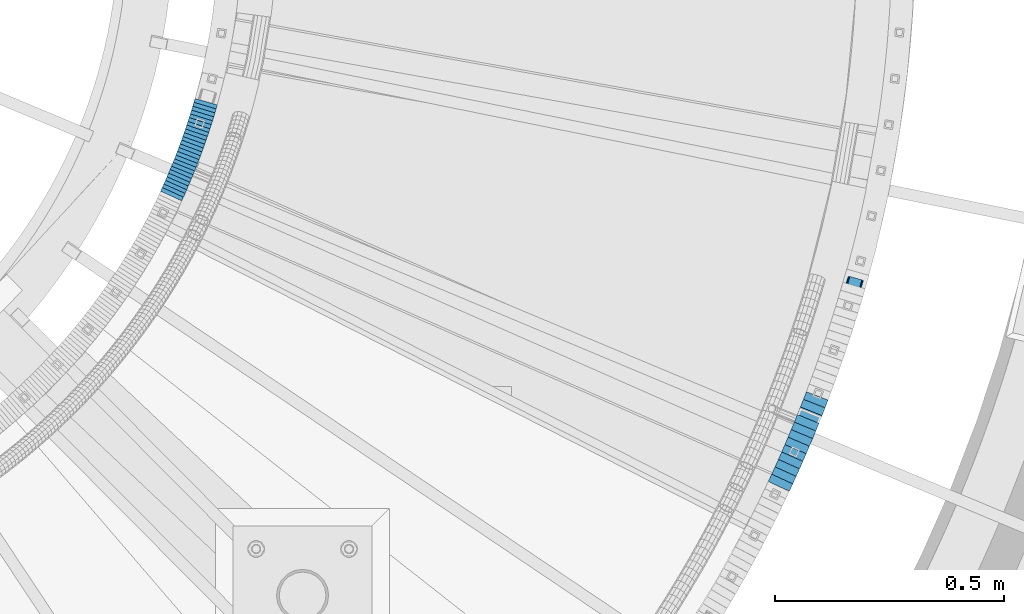
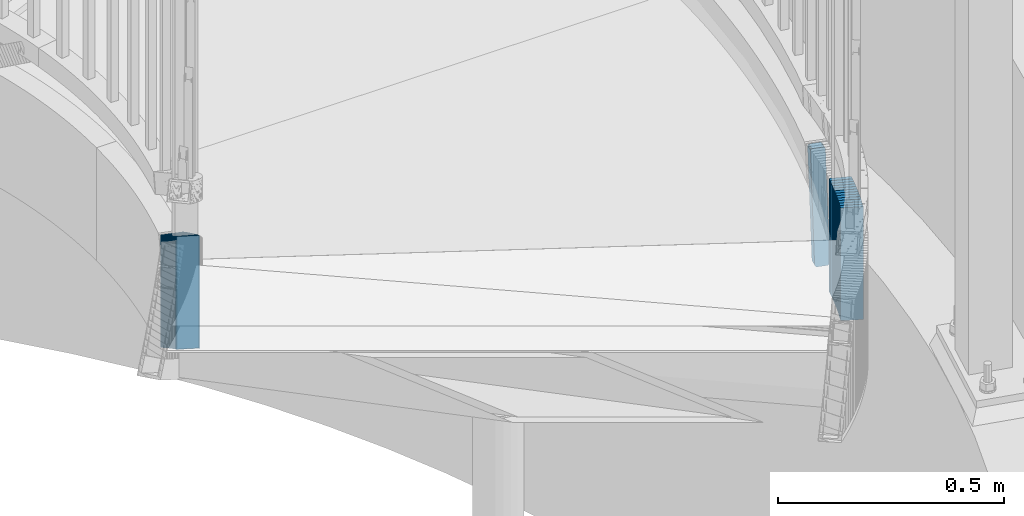
# One storey, part 908 of 975: 38 plates.
"""IFC2X3 building model written with IfcOpenShell, lengths in millimetres."""

import ifcopenshell
import ifcopenshell.guid

model = None  # the IFC model being written
_history = None  # IfcOwnerHistory: only IFC2X3 demands one
_inside = {}  # id of a spatial element -> (the spatial element, [elements in it])
_under = {}  # id of a project, library or spatial element -> (it, [spatial elements below it])
_declared = {}  # id of a project -> (the project, [libraries it declares])
_typed = {}  # id of a type object -> (the type object, [elements of that type])
_made_of = {}  # id of a material, layer set ... -> (it, [elements and type objects made of it])


def new_model(schema):
    """Start an empty IFC model of exactly this schema.

    Asked for "IFC4X3", IfcOpenShell would pick the latest addendum, in which some entities
    have other attributes; the version numbers below select the first issue.
    IFC2X3 requires an IfcOwnerHistory on every rooted entity: one is made here for all.
    """
    global model, _history
    if schema == "IFC4X3":
        model = ifcopenshell.file(schema_version=(4, 3, 0, 0))
    else:
        model = ifcopenshell.file(schema=schema)
    _inside.clear()
    _under.clear()
    _declared.clear()
    _typed.clear()
    _made_of.clear()
    _history = None
    if model.schema == "IFC2X3":
        org = make("IfcOrganization", Name="unknown")
        user = make(
            "IfcPersonAndOrganization",
            ThePerson=make("IfcPerson", FamilyName="unknown"),
            TheOrganization=org,
        )
        app = make(
            "IfcApplication",
            ApplicationDeveloper=org,
            Version="unknown",
            ApplicationFullName="unknown",
            ApplicationIdentifier="unknown",
        )
        _history = make(
            "IfcOwnerHistory",
            OwningUser=user,
            OwningApplication=app,
            ChangeAction="ADDED",
            CreationDate=0,
        )
    return model


def make(cls, **values):
    """One entity of the class cls with the attributes given. An attribute that is None is left unset."""
    return model.create_entity(
        cls, **{name: value for name, value in values.items() if value is not None}
    )


def rooted(cls, **values):
    """An entity with a GlobalId (a new one), such as an element, a storey or a relation."""
    return make(cls, GlobalId=ifcopenshell.guid.new(), OwnerHistory=_history, **values)


def si_unit(unit_type, name, prefix=None):
    """IfcSIUnit, for example si_unit("LENGTHUNIT", "METRE", prefix="MILLI")."""
    return make("IfcSIUnit", UnitType=unit_type, Prefix=prefix, Name=name)


def assignment(units):
    """IfcUnitAssignment: the units of a project."""
    return None if units is None else make("IfcUnitAssignment", Units=units)


def point(xyz):
    """IfcCartesianPoint."""
    return None if xyz is None else make("IfcCartesianPoint", Coordinates=xyz)


def direction(xyz):
    """IfcDirection."""
    return None if xyz is None else make("IfcDirection", DirectionRatios=xyz)


def frame(location, z_axis=None, x_axis=None):
    """IfcAxis2Placement3D, a coordinate frame: its origin and axes. An axis left out is left unset."""
    return make(
        "IfcAxis2Placement3D",
        Location=point(location),
        Axis=direction(z_axis),
        RefDirection=direction(x_axis),
    )


def origin_with_axes():
    """The frame at (0, 0, 0) with the z axis (0, 0, 1) and the x axis (1, 0, 0) written out."""
    return frame((0.0, 0.0, 0.0), z_axis=(0.0, 0.0, 1.0), x_axis=(1.0, 0.0, 0.0))


def place(relative_to, where):
    """IfcLocalPlacement: puts the frame where relative to a parent placement (None: the world)."""
    return make(
        "IfcLocalPlacement", PlacementRelTo=relative_to, RelativePlacement=where
    )


def context(
    kind, dimensions, precision=None, world=None, true_north=None, identifier=None
):
    """IfcGeometricRepresentationContext, for example the 3D "Model" context."""
    return make(
        "IfcGeometricRepresentationContext",
        ContextIdentifier=identifier,
        ContextType=kind,
        CoordinateSpaceDimension=dimensions,
        Precision=precision,
        WorldCoordinateSystem=world,
        TrueNorth=true_north,
    )


def subcontext(parent, identifier, kind, view, scale=None):
    """IfcGeometricRepresentationSubContext, for example "Body" below "Model"."""
    return make(
        "IfcGeometricRepresentationSubContext",
        ContextIdentifier=identifier,
        ContextType=kind,
        ParentContext=parent,
        TargetScale=scale,
        TargetView=view,
    )


def project(units=None, contexts=None):
    """IfcProject with its units and contexts."""
    return rooted(
        "IfcProject",
        Name="project",
        RepresentationContexts=contexts,
        UnitsInContext=assignment(units),
    )


def spatial(cls, under=None, at=None, **own):
    """A site, building, storey or space (cls), placed at a placement, below another one or the project."""
    s = rooted(cls, ObjectPlacement=at, **own)
    if under is not None:
        _under.setdefault(under.id(), (under, []))[1].append(s)
    return s


def faces_of(points, faces, orient=None, outer=None):
    """IfcFace entities. A face is a list of loops; a loop is a list of indices into points, from 0.

    orient and outer hold one flag for each loop. By default every Orientation is true, the
    first loop of a face is its IfcFaceOuterBound and the others are IfcFaceBound.
    """
    made = []
    for i, loops in enumerate(faces):
        bounds = []
        for j, loop in enumerate(loops):
            is_outer = j == 0 if outer is None else outer[i][j]
            bounds.append(
                make(
                    "IfcFaceOuterBound" if is_outer else "IfcFaceBound",
                    Bound=make("IfcPolyLoop", Polygon=[points[k] for k in loop]),
                    Orientation=True if orient is None else orient[i][j],
                )
            )
        made.append(make("IfcFace", Bounds=bounds))
    return made


def faceted_brep(points, faces, orient=None, outer=None, voids=None):
    """IfcFacetedBrep: a solid bounded by flat faces; with voids (closed shells), ...WithVoids."""
    shared = [point(p) for p in points]
    hull = make("IfcClosedShell", CfsFaces=faces_of(shared, faces, orient, outer))
    if voids is None:
        return make("IfcFacetedBrep", Outer=hull)
    return make(
        "IfcFacetedBrepWithVoids",
        Outer=hull,
        Voids=[
            make(cls, CfsFaces=faces_of(shared, fs, o, b)) for cls, fs, o, b in voids
        ],
    )


def shape(context_of_items, identifier, shape_type, items):
    """IfcShapeRepresentation: the items that make up one representation, for example the "Body"."""
    return make(
        "IfcShapeRepresentation",
        ContextOfItems=context_of_items,
        RepresentationIdentifier=identifier,
        RepresentationType=shape_type,
        Items=items,
    )


def material(Name=None, Category=None):
    """IfcMaterial."""
    return make("IfcMaterial", Name=Name, Category=Category)


def made_of(thing, what):
    """Note that an element or type object is made of a material, layer set ...; save() writes the relation."""
    if what is not None:
        _made_of.setdefault(what.id(), (what, []))[1].append(thing)
    return thing


def type_object(cls, material=None, **own):
    """A type object (cls), such as IfcWallType, which elements share."""
    return made_of(rooted(cls, **own), material)


def element(
    cls,
    number,
    at=None,
    inside=None,
    cuts=None,
    type_object=None,
    material=None,
    context=None,
    identifier="Body",
    shape_type=None,
    held_by="IfcProductDefinitionShape",
    body=None,
    shapes=None,
    **own,
):
    """One element of the class cls, such as IfcWall. Its Tag is "e" and its number.

    at: its placement. inside: the storey or other place that contains it. cuts: it is an
    opening in that element (IfcRelVoidsElement). A single representation is given by context,
    identifier, shape_type and body (its items); several are given by shapes. held_by: the class
    of the entity that holds the representations. save() writes the other relations.
    """
    e = rooted(cls, Tag="e%d" % number, ObjectPlacement=at, **own)
    if body is not None:
        shapes = [shape(context, identifier, shape_type, body)]
    if shapes is not None:
        e.Representation = make(held_by, Representations=shapes)
    if inside is not None:
        _inside.setdefault(inside.id(), (inside, []))[1].append(e)
    if cuts is not None:
        rooted(
            "IfcRelVoidsElement", RelatingBuildingElement=cuts, RelatedOpeningElement=e
        )
    if type_object is not None:
        _typed.setdefault(type_object.id(), (type_object, []))[1].append(e)
    return made_of(e, material)


def aggregate(whole, parts):
    """IfcRelAggregates: a whole, such as a stair, and the parts it consists of."""
    return rooted("IfcRelAggregates", RelatingObject=whole, RelatedObjects=parts)


def save(model, path):
    """Write the relations noted so far, then the file.

    IfcRelAggregates (storeys below a building ...), IfcRelContainedInSpatialStructure (elements
    in a storey), IfcRelDefinesByType, IfcRelAssociatesMaterial and IfcRelDeclares: one each for
    every whole, place, type object, material and project.
    """
    for whole, parts in _under.values():
        aggregate(whole, parts)
    for where, things in _inside.values():
        rooted(
            "IfcRelContainedInSpatialStructure",
            RelatedElements=things,
            RelatingStructure=where,
        )
    for kind, things in _typed.values():
        rooted("IfcRelDefinesByType", RelatedObjects=things, RelatingType=kind)
    for what, things in _made_of.values():
        rooted("IfcRelAssociatesMaterial", RelatedObjects=things, RelatingMaterial=what)
    for by, libraries in _declared.values():
        rooted("IfcRelDeclares", RelatingContext=by, RelatedDefinitions=libraries)
    model.write(path)


model = new_model("IFC2X3")

# Units and contexts
model_context = context("Model", 3, precision=1e-05, world=origin_with_axes())
body_context = subcontext(model_context, "Body", "Model", "MODEL_VIEW")
ifc_project = project(units=[si_unit("LENGTHUNIT", "METRE", prefix="MILLI"), si_unit("AREAUNIT", "SQUARE_METRE"), si_unit("VOLUMEUNIT", "CUBIC_METRE"), si_unit("MASSUNIT", "GRAM", prefix="KILO"), si_unit("TIMEUNIT", "SECOND"), si_unit("PLANEANGLEUNIT", "RADIAN"), si_unit("SOLIDANGLEUNIT", "STERADIAN"), si_unit("THERMODYNAMICTEMPERATUREUNIT", "DEGREE_CELSIUS"), si_unit("LUMINOUSINTENSITYUNIT", "LUMEN")], contexts=[model_context])

# Site, building, storey
site_placement = place(None, origin_with_axes())
site = spatial("IfcSite", under=ifc_project, at=site_placement, CompositionType="ELEMENT")
building_placement = place(site_placement, origin_with_axes())
building = spatial("IfcBuilding", under=site, at=building_placement, Name="Undefined", CompositionType="ELEMENT")
storey_placement = place(building_placement, origin_with_axes())
storey = spatial("IfcBuildingStorey", under=building, at=storey_placement, Name="Undefined", CompositionType="ELEMENT", Elevation=0.0)

# Plates
ifc_material = material(Name="STEEL/A36")
plate_type_1 = type_object("IfcPlateType", PredefinedType="NOTDEFINED")
plate_1_placement = place(storey_placement, frame((37513.5290251012, 2619.93228842539, 2176.46249923706), z_axis=(-0.042643257613985, -0.150480033117174, -0.987692924047308), x_axis=(-0.962114570717468, 0.272645470919916, 0.0)))
element("IfcPlate", 1, at=plate_1_placement, inside=storey, type_object=plate_type_1, material=ifc_material, Name="PLATE", context=body_context, shape_type="Brep", body=[
    faceted_brep([(0.0283717790953233, -12.6999999999807, 6.37824576082949), (1.27309277207678, -12.6999999999443, 286.203361918336), (1.27309277216409, 12.7000000000317, 286.203361918335), (0.0283717791753588, 12.6999999999916, 6.37824576082858), (1.76453448672692, -12.6999999999425, 288.624714152793), (1.76453448681423, 12.7000000000298, 288.624714152792), (3.14289941047173, -12.6999999999443, 290.675219392782), (3.14289941055904, 12.7000000000298, 290.67521939278), (5.19951556106389, -12.6999999999462, 292.044449691656), (5.1995155611512, 12.700000000028, 292.044449691655), (7.6230298552764, -12.699999999948, 292.525115966766), (7.62302985536371, 12.7000000000262, 292.525115966765), (29.8509887055552, -12.6999999999625, 292.525115966769), (29.8509887056425, 12.7000000000098, 292.525115966768), (32.2875833799626, -12.6999999999662, 292.039031578372), (32.2875833800499, 12.7000000000098, 292.039031578371), (34.3511416292095, -12.699999999968, 290.655196692296), (34.3511416292968, 12.700000000008, 290.655196692295), (35.7257379526418, -12.699999999968, 288.585472897311), (35.7257379527291, 12.7000000000044, 288.58547289731), (36.2009251618729, -12.699999999968, 286.146729623383), (36.2009251619602, 12.7000000000044, 286.146729623382), (34.9500089401045, -12.7000000000098, 6.32161346586145), (34.9500089401918, 12.6999999999643, 6.32161346586145), (34.4585271774267, -12.7000000000098, 3.90030453747113), (34.458527177514, 12.6999999999643, 3.90030453747022), (33.0801531139732, -12.700000000008, 1.84984698097833), (33.0801531140532, 12.6999999999662, 1.84984698097833), (31.0235542923692, -12.7000000000062, 0.480652861512681), (31.0235542924565, 12.6999999999662, 0.480652861511771), (28.6000724837941, -12.7000000000062, -1.63709046319127e-11), (28.6000724838814, 12.699999999968, -1.72803993336856e-11), (6.37830886230222, -12.699999999988, -3.63797880709171e-12), (6.37830886238953, 12.6999999999844, -4.54747350886464e-12), (3.94174664354068, -12.6999999999862, 0.486070902416941), (3.94174664362799, 12.699999999988, 0.486070902416031), (1.87820553164784, -12.6999999999862, 1.86986945984154), (1.87820553173515, 12.699999999988, 1.86986945984063), (0.503599638563173, -12.6999999999844, 3.93954552307878), (0.503599638650485, 12.6999999999916, 3.93954552307878)], [[[0, 1, 2, 3]], [[1, 4, 5, 2]], [[4, 6, 7, 5]], [[6, 8, 9, 7]], [[8, 10, 11, 9]], [[10, 12, 13, 11]], [[12, 14, 15, 13]], [[14, 16, 17, 15]], [[16, 18, 19, 17]], [[18, 20, 21, 19]], [[20, 22, 23, 21]], [[22, 24, 25, 23]], [[24, 26, 27, 25]], [[26, 28, 29, 27]], [[28, 30, 31, 29]], [[30, 32, 33, 31]], [[32, 34, 35, 33]], [[34, 36, 37, 35]], [[36, 38, 39, 37]], [[38, 0, 3, 39]], [[5, 7, 9, 11, 13, 15, 17, 19, 21, 23, 25, 27, 29, 31, 33, 35, 37, 39, 3, 2]], [[38, 36, 34, 32, 30, 28, 26, 24, 22, 20, 18, 16, 14, 12, 10, 8, 6, 4, 1, 0]]]),
])
plate_type_2 = type_object("IfcPlateType", PredefinedType="NOTDEFINED")
for number, where, z_axis, x_axis, name in (
    (2, (37338.9703664102, 2197.3945374098, 2024.98750006771), (-0.417626109916978, -0.908618969819369, 0.0), (0.0, 0.0, 1.0), "WALL"),
    (3, (37346.3703664099, 2213.49453740977, 2019.28750006771), (-0.417626109916978, -0.908618969819369, 0.0), (0.0, 0.0, 1.0), "WALL"),
):
    element("IfcPlate", number, at=place(storey_placement, frame(where, z_axis=z_axis, x_axis=x_axis)), inside=storey, type_object=plate_type_2, material=ifc_material, Name=name, context=body_context, shape_type="Brep", body=[
        faceted_brep([(0.0, -25.3999999999724, -1.81898940354586e-11), (5.69999980926514, -25.3999999999869, 17.7191982269287), (5.69999980926514, 25.4000000000815, 17.7191982269651), (0.0, 25.3999999999869, 1.45519152283669e-11), (310.5, -25.3999999999869, 17.7191982269287), (310.5, 25.4000000000815, 17.7191982269651), (304.799987792969, -25.3999999999724, -1.81898940354586e-11), (304.799987792969, 25.3999999999869, 1.45519152283669e-11)], [[[0, 1, 2, 3]], [[1, 4, 5, 2]], [[4, 6, 7, 5]], [[6, 0, 3, 7]], [[5, 7, 3, 2]], [[6, 4, 1, 0]]]),
    ])
plate_2_placement = place(storey_placement, frame((37353.7488983846, 2229.86709167442, 2013.68750006771), z_axis=(-0.410832634928258, -0.911710779840792, 0.0), x_axis=(0.0, 0.0, 1.0)))
element("IfcPlate", 4, at=plate_2_placement, inside=storey, type_object=plate_type_2, material=ifc_material, Name="WALL", context=body_context, shape_type="Brep", body=[
    faceted_brep([(0.0, -25.3999999999724, -1.81898940354586e-11), (5.59999990463257, -25.3999999998778, 17.76879310613), (5.59999990463257, 25.3999999999724, 17.7687931060609), (0.0, 25.3999999999869, 1.45519152283669e-11), (310.399993896485, -25.3999999998778, 17.76879310613), (310.399993896485, 25.3999999999724, 17.7687931060609), (304.799987792969, -25.3999999999724, -1.81898940354586e-11), (304.799987792969, 25.3999999999869, 1.45519152283669e-11)], [[[0, 1, 2, 3]], [[1, 4, 5, 2]], [[4, 6, 7, 5]], [[6, 0, 3, 7]], [[5, 7, 3, 2]], [[6, 4, 1, 0]]]),
])
plate_3_placement = place(storey_placement, frame((37361.002257914, 2246.18632356852, 2007.98750006771), z_axis=(-0.40613846586788, -0.913811548702732, 0.0), x_axis=(0.0, 0.0, 1.0)))
element("IfcPlate", 5, at=plate_3_placement, inside=storey, type_object=plate_type_2, material=ifc_material, Name="WALL", context=body_context, shape_type="Brep", body=[
    faceted_brep([(0.0, -25.3999999999724, -1.81898940354586e-11), (5.69999980926514, -25.3999999998996, 17.7279434204574), (5.69999980926514, 25.3999999999869, 17.7279434203992), (0.0, 25.3999999999869, 1.45519152283669e-11), (310.5, -25.3999999998996, 17.7279434204574), (310.5, 25.3999999999869, 17.7279434203992), (304.799987792969, -25.3999999999724, -1.81898940354586e-11), (304.799987792969, 25.3999999999869, 1.45519152283669e-11)], [[[0, 1, 2, 3]], [[1, 4, 5, 2]], [[4, 6, 7, 5]], [[6, 0, 3, 7]], [[5, 7, 3, 2]], [[6, 4, 1, 0]]]),
])
for number, where, z_axis, x_axis, name in (
    (6, (37368.130315909, 2262.7794124118, 2002.28750006771), (-0.394599535030015, -0.918853202069893, 0.0), (0.0, 0.0, 1.0), "WALL"),
    (7, (37375.1303159085, 2279.07941241171, 1996.58750006771), (-0.394599535030015, -0.918853202069893, 0.0), (0.0, 0.0, 1.0), "WALL"),
):
    element("IfcPlate", number, at=place(storey_placement, frame(where, z_axis=z_axis, x_axis=x_axis)), inside=storey, type_object=plate_type_2, material=ifc_material, Name=name, context=body_context, shape_type="Brep", body=[
        faceted_brep([(0.0, -25.3999999999724, -1.81898940354586e-11), (5.69999980926514, -25.3999999999833, 17.7428855895923), (5.69999980926514, 25.4000000000051, 17.7428855895996), (0.0, 25.3999999999869, 1.45519152283669e-11), (310.5, -25.3999999999833, 17.7428855895923), (310.5, 25.4000000000051, 17.7428855895996), (304.799987792969, -25.3999999999724, -1.81898940354586e-11), (304.799987792969, 25.3999999999869, 1.45519152283669e-11)], [[[0, 1, 2, 3]], [[1, 4, 5, 2]], [[4, 6, 7, 5]], [[6, 0, 3, 7]], [[5, 7, 3, 2]], [[6, 4, 1, 0]]]),
    ])
plate_4_placement = place(storey_placement, frame((37382.1036694327, 2295.65197526172, 1990.88750006771), z_axis=(-0.387805722036741, -0.92174113608733, 0.0), x_axis=(0.0, 0.0, 1.0)))
element("IfcPlate", 8, at=plate_4_placement, inside=storey, type_object=plate_type_2, material=ifc_material, Name="WALL", context=body_context, shape_type="Brep", body=[
    faceted_brep([(0.0, -25.3999999999724, -1.81898940354586e-11), (5.69999980926514, -25.4000000000251, 17.7924137116061), (5.69999980926514, 25.4000000000051, 17.7924137115479), (0.0, 25.3999999999869, 1.45519152283669e-11), (310.5, -25.4000000000251, 17.7924137116061), (310.5, 25.4000000000051, 17.7924137115479), (304.799987792969, -25.3999999999724, -1.81898940354586e-11), (304.799987792969, 25.3999999999869, 1.45519152283669e-11)], [[[0, 1, 2, 3]], [[1, 4, 5, 2]], [[4, 6, 7, 5]], [[6, 0, 3, 7]], [[5, 7, 3, 2]], [[6, 4, 1, 0]]]),
])
plate_5_placement = place(storey_placement, frame((37388.9544942598, 2312.17365902218, 1985.18750006771), z_axis=(-0.383015022804495, -0.923742113528485, 0.0), x_axis=(0.0, 0.0, 1.0)))
element("IfcPlate", 9, at=plate_5_placement, inside=storey, type_object=plate_type_2, material=ifc_material, Name="WALL", context=body_context, shape_type="Brep", body=[
    faceted_brep([(0.0, -25.3999999999724, -1.81898940354586e-11), (5.69999980926514, -25.3999999999724, 17.7538719177392), (5.69999980926514, 25.3999999999069, 17.7538719176846), (0.0, 25.3999999999869, 1.45519152283669e-11), (310.5, -25.3999999999724, 17.7538719177392), (310.5, 25.3999999999069, 17.7538719176846), (304.799987792969, -25.3999999999724, -1.81898940354586e-11), (304.799987792969, 25.3999999999869, 1.45519152283669e-11)], [[[0, 1, 2, 3]], [[1, 4, 5, 2]], [[4, 6, 7, 5]], [[6, 0, 3, 7]], [[5, 7, 3, 2]], [[6, 4, 1, 0]]]),
])
plate_6_placement = place(storey_placement, frame((37395.7252495328, 2328.84608948038, 1979.38750006771), z_axis=(-0.376226422085929, -0.926527754211616, 0.0), x_axis=(0.0, 0.0, 1.0)))
element("IfcPlate", 10, at=plate_6_placement, inside=storey, type_object=plate_type_2, material=ifc_material, Name="WALL", context=body_context, shape_type="Brep", body=[
    faceted_brep([(0.0, -25.3999999999724, -1.81898940354586e-11), (5.80000019073486, -25.3999999999542, 17.8084259032221), (5.80000019073486, 25.3999999999833, 17.8084259033567), (0.0, 25.3999999999869, 1.45519152283669e-11), (310.600006103516, -25.3999999999542, 17.8084259032221), (310.600006103516, 25.3999999999833, 17.8084259033567), (304.799987792969, -25.3999999999724, -1.81898940354586e-11), (304.799987792969, 25.3999999999869, 1.45519152283669e-11)], [[[0, 1, 2, 3]], [[1, 4, 5, 2]], [[4, 6, 7, 5]], [[6, 0, 3, 7]], [[5, 7, 3, 2]], [[6, 4, 1, 0]]]),
])
for number, where, z_axis, x_axis, name in (
    (11, (37402.3943134138, 2345.61796745032, 1973.68750006771), (-0.369459572873638, -0.929246804682173, 0.0), (0.0, 0.0, 1.0), "WALL"),
    (12, (37408.9943134128, 2362.2179674503, 1967.98750006771), (-0.369459572873638, -0.929246804682173, 0.0), (0.0, 0.0, 1.0), "WALL"),
):
    element("IfcPlate", number, at=place(storey_placement, frame(where, z_axis=z_axis, x_axis=x_axis)), inside=storey, type_object=plate_type_2, material=ifc_material, Name=name, context=body_context, shape_type="Brep", body=[
        faceted_brep([(0.0, -25.3999999999724, -1.81898940354586e-11), (5.69999980926514, -25.4000000000378, 17.8639297485788), (5.69999980926514, 25.3999999999833, 17.8639297485533), (0.0, 25.3999999999869, 1.45519152283669e-11), (310.5, -25.4000000000378, 17.8639297485788), (310.5, 25.3999999999833, 17.8639297485533), (304.799987792969, -25.3999999999724, -1.81898940354586e-11), (304.799987792969, 25.3999999999869, 1.45519152283669e-11)], [[[0, 1, 2, 3]], [[1, 4, 5, 2]], [[4, 6, 7, 5]], [[6, 0, 3, 7]], [[5, 7, 3, 2]], [[6, 4, 1, 0]]]),
    ])
plate_7_placement = place(storey_placement, frame((37415.5093869884, 2379.21272974412, 1962.28750006771), z_axis=(-0.357854758158108, -0.933777260412569, 0.0), x_axis=(0.0, 0.0, 1.0)))
element("IfcPlate", 13, at=plate_7_placement, inside=storey, type_object=plate_type_2, material=ifc_material, Name="WALL", context=body_context, shape_type="Brep", body=[
    faceted_brep([(0.0, -25.3999999999724, -1.81898940354586e-11), (5.69999980926514, -25.3999999999687, 17.8807163238307), (5.69999980926514, 25.400000000016, 17.880716323838), (0.0, 25.3999999999869, 1.45519152283669e-11), (310.5, -25.3999999999687, 17.8807163238307), (310.5, 25.400000000016, 17.880716323838), (304.799987792969, -25.3999999999724, -1.81898940354586e-11), (304.799987792969, 25.3999999999869, 1.45519152283669e-11)], [[[0, 1, 2, 3]], [[1, 4, 5, 2]], [[4, 6, 7, 5]], [[6, 0, 3, 7]], [[5, 7, 3, 2]], [[6, 4, 1, 0]]]),
])
plate_type_3 = type_object("IfcPlateType", PredefinedType="NOTDEFINED")
for number, where, z_axis, x_axis, name in (
    (14, (36005.76149874, 2824.62748633653, 2027.12500005033), (-0.415494357820709, -0.909595755607488, 0.0), (0.0, 0.0, 1.0), "WALL"),
    (15, (36009.4614987398, 2832.72748633654, 2021.42500005033), (-0.415494357820709, -0.909595755607488, 0.0), (0.0, 0.0, 1.0), "WALL"),
):
    element("IfcPlate", number, at=place(storey_placement, frame(where, z_axis=z_axis, x_axis=x_axis)), inside=storey, type_object=plate_type_3, material=ifc_material, Name=name, context=body_context, shape_type="Brep", body=[
        faceted_brep([(0.0, -25.3999999999724, -1.81898940354586e-11), (5.69999980926514, -25.4000000000269, 8.91066741947361), (5.69999980926514, 25.4000000000269, 8.91066741941904), (0.0, 25.3999999999869, 1.45519152283669e-11), (310.5, -25.4000000000269, 8.91066741947361), (310.5, 25.4000000000269, 8.91066741941904), (304.799987792969, -25.3999999999724, -1.81898940354586e-11), (304.799987792969, 25.3999999999869, 1.45519152283669e-11)], [[[0, 1, 2, 3]], [[1, 4, 5, 2]], [[4, 6, 7, 5]], [[6, 0, 3, 7]], [[5, 7, 3, 2]], [[6, 4, 1, 0]]]),
    ])
plate_8_placement = place(storey_placement, frame((36012.9544175954, 2840.58984668105, 2015.72500005033), z_axis=(-0.40613846586788, -0.913811548702732, 0.0), x_axis=(0.0, 0.0, 1.0)))
element("IfcPlate", 16, at=plate_8_placement, inside=storey, type_object=plate_type_3, material=ifc_material, Name="WALL", context=body_context, shape_type="Brep", body=[
    faceted_brep([(0.0, -25.3999999999724, -1.81898940354586e-11), (5.69999980926514, -25.4000000000378, 8.86171531681612), (5.69999980926514, 25.3999999999978, 8.86171531676882), (0.0, 25.3999999999869, 1.45519152283669e-11), (310.5, -25.4000000000378, 8.86171531681612), (310.5, 25.3999999999978, 8.86171531676882), (304.799987792969, -25.3999999999724, -1.81898940354586e-11), (304.799987792969, 25.3999999999869, 1.45519152283669e-11)], [[[0, 1, 2, 3]], [[1, 4, 5, 2]], [[4, 6, 7, 5]], [[6, 0, 3, 7]], [[5, 7, 3, 2]], [[6, 4, 1, 0]]]),
])
plate_9_placement = place(storey_placement, frame((36016.3042367866, 2848.44508567643, 2010.02500005033), z_axis=(-0.392565197976837, -0.919724178945735, 0.0), x_axis=(0.0, 0.0, 1.0)))
element("IfcPlate", 17, at=plate_9_placement, inside=storey, type_object=plate_type_3, material=ifc_material, Name="WALL", context=body_context, shape_type="Brep", body=[
    faceted_brep([(0.0, -25.3999999999724, -1.81898940354586e-11), (5.69999980926514, -25.4000000000269, 8.9196414947728), (5.69999980926514, 25.3999999999796, 8.91964149476189), (0.0, 25.3999999999869, 1.45519152283669e-11), (310.5, -25.4000000000269, 8.9196414947728), (310.5, 25.3999999999796, 8.91964149476189), (304.799987792969, -25.3999999999724, -1.81898940354586e-11), (304.799987792969, 25.3999999999869, 1.45519152283669e-11)], [[[0, 1, 2, 3]], [[1, 4, 5, 2]], [[4, 6, 7, 5]], [[6, 0, 3, 7]], [[5, 7, 3, 2]], [[6, 4, 1, 0]]]),
])
plate_10_placement = place(storey_placement, frame((36019.8488288604, 2856.64891820466, 2004.32500005033), z_axis=(-0.396653092787929, -0.917968585509205, 0.0), x_axis=(0.0, 0.0, 1.0)))
element("IfcPlate", 18, at=plate_10_placement, inside=storey, type_object=plate_type_3, material=ifc_material, Name="WALL", context=body_context, shape_type="Brep", body=[
    faceted_brep([(0.0, -25.3999999999724, -1.81898940354586e-11), (5.69999980926514, -25.399999999936, 8.82383155817661), (5.69999980926514, 25.3999999999542, 8.82383155827119), (0.0, 25.3999999999869, 1.45519152283669e-11), (310.5, -25.399999999936, 8.82383155817661), (310.5, 25.3999999999542, 8.82383155827119), (304.799987792969, -25.3999999999724, -1.81898940354586e-11), (304.799987792969, 25.3999999999869, 1.45519152283669e-11)], [[[0, 1, 2, 3]], [[1, 4, 5, 2]], [[4, 6, 7, 5]], [[6, 0, 3, 7]], [[5, 7, 3, 2]], [[6, 4, 1, 0]]]),
])
plate_11_placement = place(storey_placement, frame((36023.3042367865, 2864.74508567641, 1998.62500005033), z_axis=(-0.392565197976837, -0.919724178945735, 0.0), x_axis=(0.0, 0.0, 1.0)))
element("IfcPlate", 19, at=plate_11_placement, inside=storey, type_object=plate_type_3, material=ifc_material, Name="WALL", context=body_context, shape_type="Brep", body=[
    faceted_brep([(0.0, -25.3999999999724, -1.81898940354586e-11), (5.69999980926514, -25.4000000000269, 8.9196414947728), (5.69999980926514, 25.3999999999796, 8.91964149476189), (0.0, 25.3999999999869, 1.45519152283669e-11), (310.5, -25.4000000000269, 8.9196414947728), (310.5, 25.3999999999796, 8.91964149476189), (304.799987792969, -25.3999999999724, -1.81898940354586e-11), (304.799987792969, 25.3999999999869, 1.45519152283669e-11)], [[[0, 1, 2, 3]], [[1, 4, 5, 2]], [[4, 6, 7, 5]], [[6, 0, 3, 7]], [[5, 7, 3, 2]], [[6, 4, 1, 0]]]),
])
plate_12_placement = place(storey_placement, frame((36026.5608517434, 2872.702229547, 1992.92500005033), z_axis=(-0.379066925164675, -0.925369259401996, 0.0), x_axis=(0.0, 0.0, 1.0)))
element("IfcPlate", 20, at=plate_12_placement, inside=storey, type_object=plate_type_3, material=ifc_material, Name="WALL", context=body_context, shape_type="Brep", body=[
    faceted_brep([(0.0, -25.3999999999724, -1.81898940354586e-11), (5.69999980926514, -25.4000000000124, 8.96939277650017), (5.69999980926514, 25.3999999999869, 8.96939277651836), (0.0, 25.3999999999869, 1.45519152283669e-11), (310.5, -25.4000000000124, 8.96939277650017), (310.5, 25.3999999999869, 8.96939277651836), (304.799987792969, -25.3999999999724, -1.81898940354586e-11), (304.799987792969, 25.3999999999869, 1.45519152283669e-11)], [[[0, 1, 2, 3]], [[1, 4, 5, 2]], [[4, 6, 7, 5]], [[6, 0, 3, 7]], [[5, 7, 3, 2]], [[6, 4, 1, 0]]]),
])
plate_13_placement = place(storey_placement, frame((36029.8017928916, 2880.7567766721, 1987.22500005033), z_axis=(-0.373340434026141, -0.927694411064965, 0.0), x_axis=(0.0, 0.0, 1.0)))
element("IfcPlate", 21, at=plate_13_placement, inside=storey, type_object=plate_type_3, material=ifc_material, Name="WALL", context=body_context, shape_type="Brep", body=[
    faceted_brep([(0.0, -25.3999999999724, -1.81898940354586e-11), (5.69999980926514, -25.3999999999869, 8.84081459044683), (5.69999980926514, 25.3999999999796, 8.84081459047957), (0.0, 25.3999999999869, 1.45519152283669e-11), (310.5, -25.3999999999869, 8.84081459044683), (310.5, 25.3999999999796, 8.84081459047957), (304.799987792969, -25.3999999999724, -1.81898940354586e-11), (304.799987792969, 25.3999999999869, 1.45519152283669e-11)], [[[0, 1, 2, 3]], [[1, 4, 5, 2]], [[4, 6, 7, 5]], [[6, 0, 3, 7]], [[5, 7, 3, 2]], [[6, 4, 1, 0]]]),
])
plate_14_placement = place(storey_placement, frame((36033.2608517442, 2889.20222954704, 1981.52500005033), z_axis=(-0.379066925164675, -0.925369259401996, 0.0), x_axis=(0.0, 0.0, 1.0)))
element("IfcPlate", 22, at=plate_14_placement, inside=storey, type_object=plate_type_3, material=ifc_material, Name="WALL", context=body_context, shape_type="Brep", body=[
    faceted_brep([(0.0, -25.3999999999724, -1.81898940354586e-11), (5.69999980926514, -25.4000000000124, 8.96939277650017), (5.69999980926514, 25.3999999999869, 8.96939277651836), (0.0, 25.3999999999869, 1.45519152283669e-11), (310.5, -25.4000000000124, 8.96939277650017), (310.5, 25.3999999999869, 8.96939277651836), (304.799987792969, -25.3999999999724, -1.81898940354586e-11), (304.799987792969, 25.3999999999869, 1.45519152283669e-11)], [[[0, 1, 2, 3]], [[1, 4, 5, 2]], [[4, 6, 7, 5]], [[6, 0, 3, 7]], [[5, 7, 3, 2]], [[6, 4, 1, 0]]]),
])
plate_15_placement = place(storey_placement, frame((36036.2656194744, 2897.0111292575, 1975.72500005033), z_axis=(-0.35973226809311, -0.933055569241504, 0.0), x_axis=(0.0, 0.0, 1.0)))
element("IfcPlate", 23, at=plate_15_placement, inside=storey, type_object=plate_type_3, material=ifc_material, Name="WALL", context=body_context, shape_type="Brep", body=[
    faceted_brep([(0.0, -25.3999999999724, -1.81898940354586e-11), (5.80000019073486, -25.3999999999687, 8.90449333185097), (5.80000019073486, 25.3999999999833, 8.90449333192373), (0.0, 25.3999999999869, 1.45519152283669e-11), (310.600006103516, -25.3999999999687, 8.90449333185097), (310.600006103516, 25.3999999999833, 8.90449333192373), (304.799987792969, -25.3999999999724, -1.81898940354586e-11), (304.799987792969, 25.3999999999869, 1.45519152283669e-11)], [[[0, 1, 2, 3]], [[1, 4, 5, 2]], [[4, 6, 7, 5]], [[6, 0, 3, 7]], [[5, 7, 3, 2]], [[6, 4, 1, 0]]]),
])
plate_16_placement = place(storey_placement, frame((36039.4292424693, 2905.3162109772, 1970.02500005033), z_axis=(-0.355995327924662, -0.934487734802235, 0.0), x_axis=(0.0, 0.0, 1.0)))
element("IfcPlate", 24, at=plate_16_placement, inside=storey, type_object=plate_type_3, material=ifc_material, Name="WALL", context=body_context, shape_type="Brep", body=[
    faceted_brep([(0.0, -25.3999999999724, -1.81898940354586e-11), (5.69999980926514, -25.4000000000196, 8.98721313477654), (5.69999980926514, 25.4000000000669, 8.98721313470742), (0.0, 25.3999999999869, 1.45519152283669e-11), (310.5, -25.4000000000196, 8.98721313477654), (310.5, 25.4000000000669, 8.98721313470742), (304.799987792969, -25.3999999999724, -1.81898940354586e-11), (304.799987792969, 25.3999999999869, 1.45519152283669e-11)], [[[0, 1, 2, 3]], [[1, 4, 5, 2]], [[4, 6, 7, 5]], [[6, 0, 3, 7]], [[5, 7, 3, 2]], [[6, 4, 1, 0]]]),
])
plate_17_placement = place(storey_placement, frame((36042.6656194745, 2913.71112925751, 1964.32500005033), z_axis=(-0.35973226809311, -0.933055569241504, 0.0), x_axis=(0.0, 0.0, 1.0)))
element("IfcPlate", 25, at=plate_17_placement, inside=storey, type_object=plate_type_3, material=ifc_material, Name="WALL", context=body_context, shape_type="Brep", body=[
    faceted_brep([(0.0, -25.3999999999724, -1.81898940354586e-11), (5.69999980926514, -25.3999999999469, 8.90224647518698), (5.69999980926514, 25.399999999936, 8.90224647526338), (0.0, 25.3999999999869, 1.45519152283669e-11), (310.5, -25.3999999999469, 8.90224647518698), (310.5, 25.399999999936, 8.90224647526338), (304.799987792969, -25.3999999999724, -1.81898940354586e-11), (304.799987792969, 25.3999999999869, 1.45519152283669e-11)], [[[0, 1, 2, 3]], [[1, 4, 5, 2]], [[4, 6, 7, 5]], [[6, 0, 3, 7]], [[5, 7, 3, 2]], [[6, 4, 1, 0]]]),
])
plate_18_placement = place(storey_placement, frame((36045.6361626974, 2921.76799054339, 1958.52500005033), z_axis=(-0.346222869900943, -0.938152292731598, 0.0), x_axis=(0.0, 0.0, 1.0)))
element("IfcPlate", 26, at=plate_18_placement, inside=storey, type_object=plate_type_3, material=ifc_material, Name="WALL", context=body_context, shape_type="Brep", body=[
    faceted_brep([(0.0, -25.3999999999724, -1.81898940354586e-11), (5.80000019073486, -25.3999999999942, 8.94930171964734), (5.80000019073486, 25.4000000000015, 8.94930171966917), (0.0, 25.3999999999869, 1.45519152283669e-11), (310.600006103516, -25.3999999999942, 8.94930171964734), (310.600006103516, 25.4000000000015, 8.94930171966917), (304.799987792969, -25.3999999999724, -1.81898940354586e-11), (304.799987792969, 25.3999999999869, 1.45519152283669e-11)], [[[0, 1, 2, 3]], [[1, 4, 5, 2]], [[4, 6, 7, 5]], [[6, 0, 3, 7]], [[5, 7, 3, 2]], [[6, 4, 1, 0]]]),
])
plate_19_placement = place(storey_placement, frame((36048.7361626971, 2930.1679905434, 1952.82500005033), z_axis=(-0.346222869900943, -0.938152292731598, 0.0), x_axis=(0.0, 0.0, 1.0)))
element("IfcPlate", 27, at=plate_19_placement, inside=storey, type_object=plate_type_3, material=ifc_material, Name="WALL", context=body_context, shape_type="Brep", body=[
    faceted_brep([(0.0, -25.3999999999724, -1.81898940354586e-11), (5.69999980926514, -25.3999999999869, 8.94930171964734), (5.69999980926514, 25.4000000000051, 8.94930171966917), (0.0, 25.3999999999869, 1.45519152283669e-11), (310.5, -25.3999999999869, 8.94930171964734), (310.5, 25.4000000000051, 8.94930171966917), (304.799987792969, -25.3999999999724, -1.81898940354586e-11), (304.799987792969, 25.3999999999869, 1.45519152283669e-11)], [[[0, 1, 2, 3]], [[1, 4, 5, 2]], [[4, 6, 7, 5]], [[6, 0, 3, 7]], [[5, 7, 3, 2]], [[6, 4, 1, 0]]]),
])
for number, where, z_axis, x_axis, name in (
    (28, (36051.6132764604, 2938.327560641, 1947.02500005033), (-0.332820117839757, -0.942990333545965, 0.0), (0.0, 0.0, 1.0), "WALL"),
    (29, (36054.6132764604, 2946.82756064101, 1941.22500005033), (-0.332820117839757, -0.942990333545965, 0.0), (0.0, 0.0, 1.0), "WALL"),
):
    element("IfcPlate", number, at=place(storey_placement, frame(where, z_axis=z_axis, x_axis=x_axis)), inside=storey, type_object=plate_type_3, material=ifc_material, Name=name, context=body_context, shape_type="Brep", body=[
        faceted_brep([(0.0, -25.3999999999724, -1.81898940354586e-11), (5.80000019073486, -25.400000000016, 9.01387786866326), (5.80000019073486, 25.4000000000306, 9.01387786864143), (0.0, 25.3999999999869, 1.45519152283669e-11), (310.600006103515, -25.400000000016, 9.01387786866326), (310.600006103515, 25.4000000000306, 9.01387786864143), (304.799987792969, -25.3999999999724, -1.81898940354586e-11), (304.799987792969, 25.3999999999869, 1.45519152283669e-11)], [[[0, 1, 2, 3]], [[1, 4, 5, 2]], [[4, 6, 7, 5]], [[6, 0, 3, 7]], [[5, 7, 3, 2]], [[6, 4, 1, 0]]]),
    ])
plate_20_placement = place(storey_placement, frame((36057.4258359396, 2955.07560559699, 1935.52500005033), z_axis=(-0.322900627911091, -0.946432873739402, 0.0), x_axis=(0.0, 0.0, 1.0)))
element("IfcPlate", 30, at=plate_20_placement, inside=storey, type_object=plate_type_3, material=ifc_material, Name="WALL", context=body_context, shape_type="Brep", body=[
    faceted_brep([(0.0, -25.3999999999724, -1.81898940354586e-11), (5.69999980926514, -25.3999999999542, 8.98276138300935), (5.69999980926514, 25.3999999999614, 8.98276138309302), (0.0, 25.3999999999869, 1.45519152283669e-11), (310.5, -25.3999999999542, 8.98276138300935), (310.5, 25.3999999999614, 8.98276138309302), (304.799987792969, -25.3999999999724, -1.81898940354586e-11), (304.799987792969, 25.3999999999869, 1.45519152283669e-11)], [[[0, 1, 2, 3]], [[1, 4, 5, 2]], [[4, 6, 7, 5]], [[6, 0, 3, 7]], [[5, 7, 3, 2]], [[6, 4, 1, 0]]]),
])
plate_21_placement = place(storey_placement, frame((36060.3258359398, 2963.575605597, 1929.72500005033), z_axis=(-0.322900627911091, -0.946432873739402, 0.0), x_axis=(0.0, 0.0, 1.0)))
element("IfcPlate", 31, at=plate_21_placement, inside=storey, type_object=plate_type_3, material=ifc_material, Name="WALL", context=body_context, shape_type="Brep", body=[
    faceted_brep([(0.0, -25.3999999999724, -1.81898940354586e-11), (5.80000019073486, -25.3999999999432, 8.98109149925949), (5.80000019073486, 25.3999999999651, 8.98109149937954), (0.0, 25.3999999999869, 1.45519152283669e-11), (310.600006103516, -25.3999999999432, 8.98109149925949), (310.600006103516, 25.3999999999651, 8.98109149937954), (304.799987792969, -25.3999999999724, -1.81898940354586e-11), (304.799987792969, 25.3999999999869, 1.45519152283669e-11)], [[[0, 1, 2, 3]], [[1, 4, 5, 2]], [[4, 6, 7, 5]], [[6, 0, 3, 7]], [[5, 7, 3, 2]], [[6, 4, 1, 0]]]),
])
plate_22_placement = place(storey_placement, frame((36063.0404434947, 2971.82091845316, 1923.92500005033), z_axis=(-0.312873575008118, -0.949794781024638, 0.0), x_axis=(0.0, 0.0, 1.0)))
element("IfcPlate", 32, at=plate_22_placement, inside=storey, type_object=plate_type_3, material=ifc_material, Name="WALL", context=body_context, shape_type="Brep", body=[
    faceted_brep([(0.0, -25.3999999999724, -1.81898940354586e-11), (5.80000019073486, -25.3999999999942, 8.94930171964734), (5.80000019073486, 25.4000000000015, 8.94930171966917), (0.0, 25.3999999999869, 1.45519152283669e-11), (310.600006103516, -25.3999999999942, 8.94930171964734), (310.600006103516, 25.4000000000015, 8.94930171966917), (304.799987792969, -25.3999999999724, -1.81898940354586e-11), (304.799987792969, 25.3999999999869, 1.45519152283669e-11)], [[[0, 1, 2, 3]], [[1, 4, 5, 2]], [[4, 6, 7, 5]], [[6, 0, 3, 7]], [[5, 7, 3, 2]], [[6, 4, 1, 0]]]),
])
plate_23_placement = place(storey_placement, frame((36065.8130965705, 2980.33741524653, 1918.12500005033), z_axis=(-0.309586046893062, -0.950871431671562, 0.0), x_axis=(0.0, 0.0, 1.0)))
element("IfcPlate", 33, at=plate_23_placement, inside=storey, type_object=plate_type_3, material=ifc_material, Name="WALL", context=body_context, shape_type="Brep", body=[
    faceted_brep([(0.0, -25.3999999999724, -1.81898940354586e-11), (5.80000019073486, -25.3999999999942, 9.04267692565918), (5.80000019073486, 25.3999999999614, 9.04267692568101), (0.0, 25.3999999999869, 1.45519152283669e-11), (310.600006103516, -25.3999999999942, 9.04267692565918), (310.600006103516, 25.3999999999614, 9.04267692568101), (304.799987792969, -25.3999999999724, -1.81898940354586e-11), (304.799987792969, 25.3999999999869, 1.45519152283669e-11)], [[[0, 1, 2, 3]], [[1, 4, 5, 2]], [[4, 6, 7, 5]], [[6, 0, 3, 7]], [[5, 7, 3, 2]], [[6, 4, 1, 0]]]),
])
plate_24_placement = place(storey_placement, frame((36068.4314887592, 2988.68219753671, 1912.32500005033), z_axis=(-0.299538105855776, -0.954084337540625, 0.0), x_axis=(0.0, 0.0, 1.0)))
element("IfcPlate", 34, at=plate_24_placement, inside=storey, type_object=plate_type_3, material=ifc_material, Name="WALL", context=body_context, shape_type="Brep", body=[
    faceted_brep([(0.0, -25.3999999999724, -1.81898940354586e-11), (5.80000019073486, -25.400000000016, 9.01387786866326), (5.80000019073486, 25.4000000000306, 9.01387786864143), (0.0, 25.3999999999869, 1.45519152283669e-11), (310.600006103515, -25.400000000016, 9.01387786866326), (310.600006103515, 25.4000000000306, 9.01387786864143), (304.799987792969, -25.3999999999724, -1.81898940354586e-11), (304.799987792969, 25.3999999999869, 1.45519152283669e-11)], [[[0, 1, 2, 3]], [[1, 4, 5, 2]], [[4, 6, 7, 5]], [[6, 0, 3, 7]], [[5, 7, 3, 2]], [[6, 4, 1, 0]]]),
])
plate_25_placement = place(storey_placement, frame((36071.1066018581, 2997.30246970739, 1906.52500005033), z_axis=(-0.296399214935358, -0.955064136791715, 0.0), x_axis=(0.0, 0.0, 1.0)))
element("IfcPlate", 35, at=plate_25_placement, inside=storey, type_object=plate_type_3, material=ifc_material, Name="WALL", context=body_context, shape_type="Brep", body=[
    faceted_brep([(0.0, -25.3999999999724, -1.81898940354586e-11), (5.80000019073486, -25.4000000000051, 9.10659122468314), (5.80000019073486, 25.3999999999687, 9.1065912246886), (0.0, 25.3999999999869, 1.45519152283669e-11), (310.600006103516, -25.4000000000051, 9.10659122468314), (310.600006103516, 25.3999999999687, 9.1065912246886), (304.799987792969, -25.3999999999724, -1.81898940354586e-11), (304.799987792969, 25.3999999999869, 1.45519152283669e-11)], [[[0, 1, 2, 3]], [[1, 4, 5, 2]], [[4, 6, 7, 5]], [[6, 0, 3, 7]], [[5, 7, 3, 2]], [[6, 4, 1, 0]]]),
])
plate_26_placement = place(storey_placement, frame((36073.6520606779, 3005.72442297611, 1900.72500005033), z_axis=(-0.289389501105856, -0.957211427350146, 0.0), x_axis=(0.0, 0.0, 1.0)))
element("IfcPlate", 36, at=plate_26_placement, inside=storey, type_object=plate_type_3, material=ifc_material, Name="WALL", context=body_context, shape_type="Brep", body=[
    faceted_brep([(0.0, -25.3999999999724, -1.81898940354586e-11), (5.80000019073486, -25.3999999999432, 8.98109149925949), (5.80000019073486, 25.3999999999651, 8.98109149937954), (0.0, 25.3999999999869, 1.45519152283669e-11), (310.600006103516, -25.3999999999432, 8.98109149925949), (310.600006103516, 25.3999999999651, 8.98109149937954), (304.799987792969, -25.3999999999724, -1.81898940354586e-11), (304.799987792969, 25.3999999999869, 1.45519152283669e-11)], [[[0, 1, 2, 3]], [[1, 4, 5, 2]], [[4, 6, 7, 5]], [[6, 0, 3, 7]], [[5, 7, 3, 2]], [[6, 4, 1, 0]]]),
])
plate_27_placement = place(storey_placement, frame((36076.2287578441, 3014.34689861553, 1894.92500005033), z_axis=(-0.286337360928148, -0.958128861759578, 0.0), x_axis=(0.0, 0.0, 1.0)))
element("IfcPlate", 37, at=plate_27_placement, inside=storey, type_object=plate_type_3, material=ifc_material, Name="WALL", context=body_context, shape_type="Brep", body=[
    faceted_brep([(0.0, -25.3999999999724, -1.81898940354586e-11), (5.80000019073486, -25.4000000000815, 9.08019828793476), (5.80000019073486, 25.4000000000742, 9.08019828799115), (0.0, 25.3999999999869, 1.45519152283669e-11), (310.600006103516, -25.4000000000815, 9.08019828793476), (310.600006103516, 25.4000000000742, 9.08019828799115), (304.799987792969, -25.3999999999724, -1.81898940354586e-11), (304.799987792969, 25.3999999999869, 1.45519152283669e-11)], [[[0, 1, 2, 3]], [[1, 4, 5, 2]], [[4, 6, 7, 5]], [[6, 0, 3, 7]], [[5, 7, 3, 2]], [[6, 4, 1, 0]]]),
])
plate_28_placement = place(storey_placement, frame((36078.6531394134, 3022.78889847535, 1889.12500005033), z_axis=(-0.276179875094786, -0.961105965329853, 0.0), x_axis=(0.0, 0.0, 1.0)))
element("IfcPlate", 38, at=plate_28_placement, inside=storey, type_object=plate_type_3, material=ifc_material, Name="WALL", context=body_context, shape_type="Brep", body=[
    faceted_brep([(0.0, -25.3999999999724, -1.81898940354586e-11), (5.80000019073486, -25.4000000000669, 9.05207157133191), (5.80000019073486, 25.4000000000669, 9.05207157136647), (0.0, 25.3999999999869, 1.45519152283669e-11), (310.600006103515, -25.4000000000669, 9.05207157133191), (310.600006103515, 25.4000000000669, 9.05207157136647), (304.799987792969, -25.3999999999724, -1.81898940354586e-11), (304.799987792969, 25.3999999999869, 1.45519152283669e-11)], [[[0, 1, 2, 3]], [[1, 4, 5, 2]], [[4, 6, 7, 5]], [[6, 0, 3, 7]], [[5, 7, 3, 2]], [[6, 4, 1, 0]]]),
])

save(model, "model.ifc")
